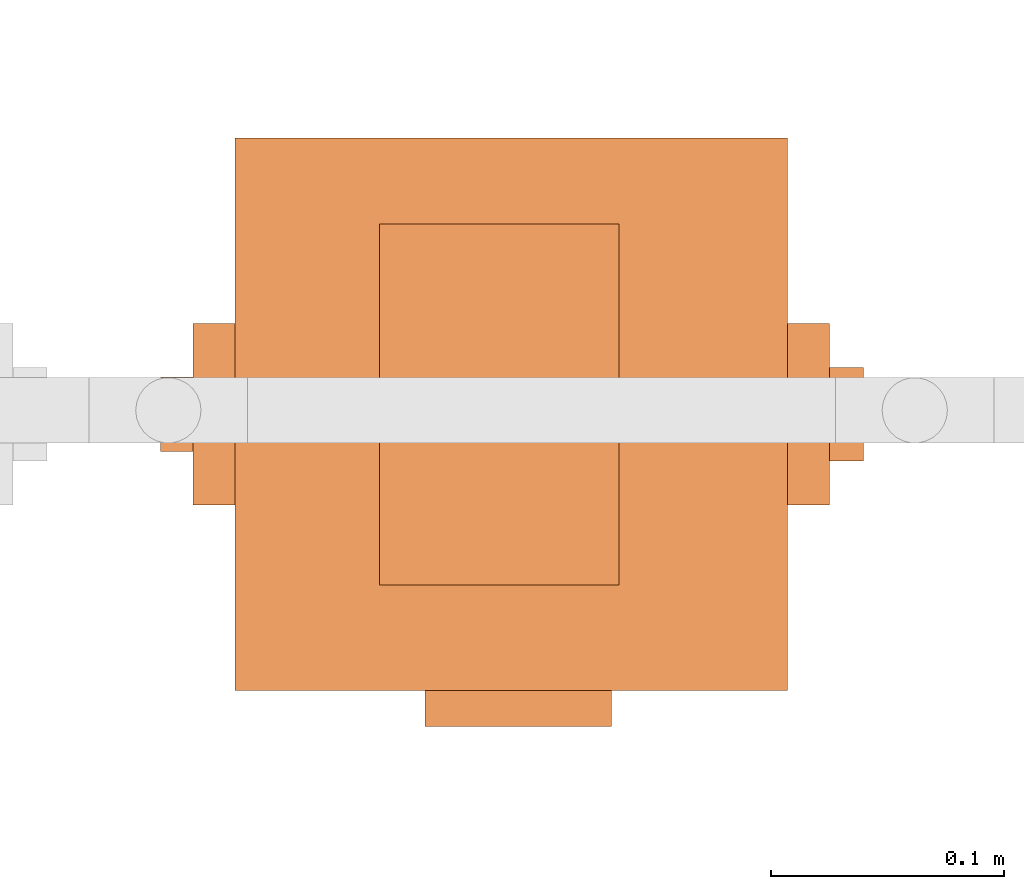
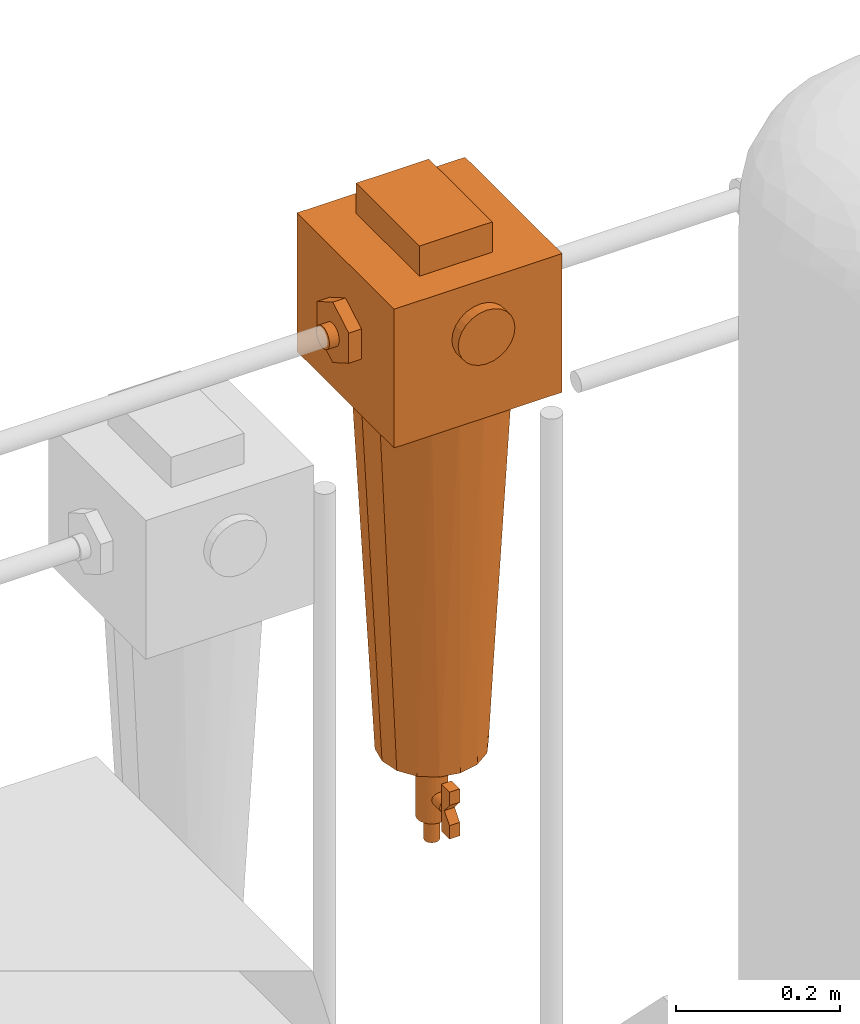
# One storey, part 330 of 331: 1 proxy.
"""IFC2X3 building model written with IfcOpenShell, lengths in millimetres."""

from ifc_helpers import new_model, entity, si_unit, converted_unit, derived_unit, direction, frame, origin, place, context, subcontext, project, spatial, faceted_brep, source, transform, mapped, material, material_list, type_object, type_shapes, element, save


model = new_model("IFC2X3")

# Units and contexts
model_context = context("Model", 3, precision=0.01, world=origin(), true_north=direction((6.12303176911189e-17, 1.0)))
body_context = subcontext(model_context, "Body", "Model", "MODEL_VIEW")
ifc_project = project(units=[si_unit("LENGTHUNIT", "METRE", prefix="MILLI"), si_unit("AREAUNIT", "SQUARE_METRE"), si_unit("VOLUMEUNIT", "CUBIC_METRE"), converted_unit("PLANEANGLEUNIT", "DEGREE", entity("IfcRatioMeasure", 0.0174532925199433), si_unit("PLANEANGLEUNIT", "RADIAN"), dimensions=[0, 0, 0, 0, 0, 0, 0]), si_unit("MASSUNIT", "GRAM", prefix="KILO"), derived_unit("MASSDENSITYUNIT", [(si_unit("MASSUNIT", "GRAM", prefix="KILO"), 1), (si_unit("LENGTHUNIT", "METRE"), -3)]), derived_unit("MOMENTOFINERTIAUNIT", [(si_unit("LENGTHUNIT", "METRE"), 4)]), si_unit("TIMEUNIT", "SECOND"), si_unit("FREQUENCYUNIT", "HERTZ"), si_unit("THERMODYNAMICTEMPERATUREUNIT", "DEGREE_CELSIUS"), derived_unit("THERMALTRANSMITTANCEUNIT", [(si_unit("MASSUNIT", "GRAM", prefix="KILO"), 1), (si_unit("THERMODYNAMICTEMPERATUREUNIT", "KELVIN"), -1), (si_unit("TIMEUNIT", "SECOND"), -3)]), derived_unit("VOLUMETRICFLOWRATEUNIT", [(si_unit("LENGTHUNIT", "METRE"), 3), (si_unit("TIMEUNIT", "SECOND"), -1)]), derived_unit("MASSFLOWRATEUNIT", [(si_unit("MASSUNIT", "GRAM", prefix="KILO"), 1), (si_unit("TIMEUNIT", "SECOND"), -1)]), derived_unit("ROTATIONALFREQUENCYUNIT", [(si_unit("TIMEUNIT", "SECOND"), -1)]), si_unit("ELECTRICCURRENTUNIT", "AMPERE"), si_unit("ELECTRICVOLTAGEUNIT", "VOLT"), si_unit("POWERUNIT", "WATT"), si_unit("FORCEUNIT", "NEWTON", prefix="KILO"), si_unit("ILLUMINANCEUNIT", "LUX"), si_unit("LUMINOUSFLUXUNIT", "LUMEN"), si_unit("LUMINOUSINTENSITYUNIT", "CANDELA"), derived_unit("USERDEFINED", [(si_unit("MASSUNIT", "GRAM", prefix="KILO"), -1), (si_unit("LENGTHUNIT", "METRE"), -2), (si_unit("TIMEUNIT", "SECOND"), 3), (si_unit("LUMINOUSFLUXUNIT", "LUMEN"), 1)]), derived_unit("LINEARVELOCITYUNIT", [(si_unit("LENGTHUNIT", "METRE"), 1), (si_unit("TIMEUNIT", "SECOND"), -1)]), si_unit("PRESSUREUNIT", "PASCAL"), derived_unit("USERDEFINED", [(si_unit("LENGTHUNIT", "METRE"), -2), (si_unit("MASSUNIT", "GRAM", prefix="KILO"), 1), (si_unit("TIMEUNIT", "SECOND"), -2)]), derived_unit("LINEARFORCEUNIT", [(si_unit("MASSUNIT", "GRAM", prefix="KILO"), 1), (si_unit("LENGTHUNIT", "METRE"), 1), (si_unit("TIMEUNIT", "SECOND"), -2), (si_unit("LENGTHUNIT", "METRE"), -1)]), derived_unit("PLANARFORCEUNIT", [(si_unit("MASSUNIT", "GRAM", prefix="KILO"), 1), (si_unit("LENGTHUNIT", "METRE"), 1), (si_unit("TIMEUNIT", "SECOND"), -2), (si_unit("LENGTHUNIT", "METRE"), -2)])], contexts=[model_context])

# Site, building, storey
site_placement = place(None, frame((0.0, -0.00077364408347762, 0.0)))
site = spatial("IfcSite", under=ifc_project, at=site_placement, CompositionType="ELEMENT")
building_placement = place(site_placement, origin())
building = spatial("IfcBuilding", under=site, at=building_placement, CompositionType="ELEMENT")
storey_placement = place(building_placement, origin())
storey = spatial("IfcBuildingStorey", under=building, at=storey_placement, CompositionType="ELEMENT", Elevation=0.0)

# Proxy
ifc_material_1 = material()
ifc_material_2 = material()
ifc_material_list = material_list([ifc_material_1, ifc_material_2])
building_element_proxy_type = type_object("IfcBuildingElementProxyType", PredefinedType="NOTDEFINED", material=ifc_material_1)
shared_shape = source(origin(), body_context, "Body", "Brep", [
    faceted_brep([(0.0, -133.944326212679, 215.362410286268), (-10.3527618041006, -133.944326212679, 213.999443337831), (-20.0, -133.944326212679, 210.003426437646), (-28.2842712474617, -133.944326212679, 203.64668153373), (-34.6410161513774, -133.944326212679, 195.362410286268), (-38.6370330515627, -133.944326212679, 185.715172090369), (-40.0, -133.944326212679, 175.362410286268), (-38.6370330515627, -133.944326212679, 165.009648482167), (-34.6410161513776, -133.944326212679, 155.362410286268), (-28.2842712474619, -133.944326212679, 147.078139038806), (-20.0, -133.944326212679, 140.721394134891), (-10.3527618041009, -133.944326212679, 136.725377234705), (0.0, -133.944326212679, 135.362410286268), (10.3527618041008, -133.944326212679, 136.725377234705), (20.0, -133.944326212679, 140.721394134891), (28.2842712474618, -133.944326212679, 147.078139038806), (34.6410161513775, -133.944326212679, 155.362410286268), (38.6370330515627, -133.944326212679, 165.009648482167), (40.0, -133.944326212679, 175.362410286268), (38.6370330515628, -133.944326212679, 185.715172090369), (34.6410161513776, -133.944326212679, 195.362410286268), (28.284271247462, -133.944326212679, 203.64668153373), (20.0, -133.944326212679, 210.003426437646), (10.352761804101, -133.944326212679, 213.999443337831), (0.0, -118.499999999999, 135.362410286268), (-10.3527618041009, -118.499999999999, 136.725377234705), (-20.0, -118.499999999999, 140.721394134891), (-28.2842712474619, -118.499999999999, 147.078139038806), (-34.6410161513776, -118.499999999999, 155.362410286268), (-38.6370330515627, -118.499999999999, 165.009648482167), (-40.0, -118.499999999999, 175.362410286268), (-38.6370330515627, -118.499999999999, 185.715172090369), (-34.6410161513774, -118.499999999999, 195.362410286268), (-28.2842712474617, -118.499999999999, 203.64668153373), (-20.0, -118.499999999999, 210.003426437646), (-10.3527618041006, -118.499999999999, 213.999443337831), (0.0, -118.499999999999, 215.362410286268), (10.352761804101, -118.499999999999, 213.999443337831), (20.0, -118.499999999999, 210.003426437646), (28.284271247462, -118.499999999999, 203.64668153373), (34.6410161513776, -118.499999999999, 195.362410286268), (38.6370330515628, -118.499999999999, 185.715172090369), (40.0, -118.499999999999, 175.362410286268), (38.6370330515627, -118.499999999999, 165.009648482167), (34.6410161513775, -118.499999999999, 155.362410286268), (28.2842712474618, -118.499999999999, 147.078139038806), (20.0, -118.499999999999, 140.721394134891), (10.3527618041008, -118.499999999999, 136.725377234705)], [[[0, 1, 2, 3, 4, 5, 6, 7, 8, 9, 10, 11, 12, 13, 14, 15, 16, 17, 18, 19, 20, 21, 22, 23]], [[24, 25, 26, 27, 28, 29, 30, 31, 32, 33, 34, 35, 36, 37, 38, 39, 40, 41, 42, 43, 44, 45, 46, 47]], [[41, 19, 18, 42]], [[40, 20, 19, 41]], [[22, 21, 39, 38]], [[40, 39, 21, 20]], [[23, 22, 38, 37]], [[0, 23, 37, 36]], [[35, 1, 0, 36]], [[34, 2, 1, 35]], [[4, 3, 33, 32]], [[34, 33, 3, 2]], [[5, 4, 32, 31]], [[6, 5, 31, 30]], [[29, 7, 6, 30]], [[28, 8, 7, 29]], [[10, 9, 27, 26]], [[28, 27, 9, 8]], [[11, 10, 26, 25]], [[12, 11, 25, 24]], [[47, 13, 12, 24]], [[46, 14, 13, 47]], [[16, 15, 45, 44]], [[46, 45, 15, 14]], [[17, 16, 44, 43]], [[18, 17, 43, 42]]]),
    faceted_brep([(43.1099584355239, 81.5000000000009, 295.027035784925), (-59.5, 81.5000000000009, 295.027035784925), (-59.5, -73.1694472627613, 295.027035784925), (43.1099584355239, -73.1694472627613, 295.027035784925), (43.1099584355239, 81.5000000000009, 250.0), (43.1099584355239, -73.1694472627613, 250.0), (-59.5, -73.1694472627613, 250.0), (-59.5, 81.5000000000009, 250.0)], [[[0, 1, 2, 3]], [[4, 5, 6, 7]], [[1, 0, 4, 7]], [[2, 1, 7, 6]], [[3, 2, 6, 5]], [[0, 3, 5, 4]]]),
    faceted_brep([(6.83332917429858, -36.7004123407108, -547.095544544356), (6.83332917429858, -56.7004123407108, -547.095544544356), (6.83332917429858, -56.7004123407108, -567.095544544356), (6.83332917429858, -44.1139178730516, -582.095544544356), (6.83332917429858, -56.7004123407108, -597.095544544356), (6.83332917429858, -56.7004123407109, -617.095544544356), (6.83332917429858, -36.7004123407109, -617.095544544356), (6.83332917429858, -36.7004123407108, -582.095544544356), (-7.69905295378288, -36.7004123407108, -547.095544544356), (-7.69905295378288, -36.7004123407108, -582.095544544356), (-7.69905295378288, -36.7004123407109, -617.095544544356), (-7.69905295378288, -56.7004123407109, -617.095544544356), (-7.69905295378288, -56.7004123407108, -597.095544544356), (-7.69905295378288, -44.1139178730516, -582.095544544356), (-7.69905295378288, -56.7004123407108, -567.095544544356), (-7.69905295378288, -56.7004123407108, -547.095544544356)], [[[0, 1, 2, 3, 4, 5, 6, 7]], [[8, 9, 10, 11, 12, 13, 14, 15]], [[1, 0, 8, 15]], [[2, 1, 15, 14]], [[3, 2, 14, 13]], [[4, 3, 13, 12]], [[5, 4, 12, 11]], [[6, 5, 11, 10]], [[7, 6, 10, 9]], [[0, 7, 9, 8]]]),
    faceted_brep([(-5.0, -36.7004123407108, -573.435290506511), (-7.07106781186544, -36.7004123407108, -575.02447673249), (-8.66025403784436, -36.7004123407108, -577.095544544356), (-9.65925826289067, -36.7004123407108, -579.50735409333), (-10.0, -36.7004123407108, -582.095544544356), (-9.65925826289068, -36.7004123407108, -584.683734995381), (-8.66025403784439, -36.7004123407108, -587.095544544356), (-7.07106781186548, -36.7004123407108, -589.166612356221), (-5.0, -36.7004123407108, -590.7557985822), (-2.58819045102522, -36.7004123407108, -591.754802807246), (0.0, -36.7004123407108, -592.095544544356), (2.58819045102519, -36.7004123407108, -591.754802807246), (5.0, -36.7004123407108, -590.7557985822), (7.07106781186546, -36.7004123407108, -589.166612356221), (8.66025403784437, -36.7004123407108, -587.095544544356), (9.65925826289068, -36.7004123407108, -584.683734995381), (10.0, -36.7004123407108, -582.095544544356), (9.65925826289069, -36.7004123407108, -579.50735409333), (8.66025403784441, -36.7004123407108, -577.095544544356), (7.0710678118655, -36.7004123407108, -575.02447673249), (5.0, -36.7004123407108, -573.435290506511), (2.58819045102525, -36.7004123407108, -572.436286281465), (0.0, -36.7004123407108, -572.095544544356), (-2.58819045102516, -36.7004123407108, -572.436286281465), (2.58819045102519, -9.5868948994194, -591.754802807246), (0.0, -9.5868948994194, -592.095544544356), (-2.58819045102522, -9.5868948994194, -591.754802807246), (-5.0, -9.5868948994194, -590.7557985822), (-7.07106781186548, -9.5868948994194, -589.166612356221), (-8.66025403784439, -9.5868948994194, -587.095544544356), (-9.65925826289068, -9.5868948994194, -584.683734995381), (-10.0, -9.5868948994194, -582.095544544356), (-9.65925826289067, -9.5868948994194, -579.50735409333), (-8.66025403784436, -9.5868948994194, -577.095544544356), (-7.07106781186544, -9.5868948994194, -575.02447673249), (-5.0, -9.5868948994194, -573.435290506511), (-2.58819045102516, -9.5868948994194, -572.436286281465), (0.0, -9.5868948994194, -572.095544544356), (2.58819045102525, -9.5868948994194, -572.436286281465), (5.0, -9.5868948994194, -573.435290506511), (7.0710678118655, -9.5868948994194, -575.02447673249), (8.66025403784441, -9.5868948994194, -577.095544544356), (9.65925826289069, -9.5868948994194, -579.50735409333), (10.0, -9.5868948994194, -582.095544544356), (9.65925826289068, -9.5868948994194, -584.683734995381), (8.66025403784437, -9.5868948994194, -587.095544544356), (7.07106781186546, -9.5868948994194, -589.166612356221), (5.0, -9.5868948994194, -590.7557985822)], [[[0, 1, 2, 3, 4, 5, 6, 7, 8, 9, 10, 11, 12, 13, 14, 15, 16, 17, 18, 19, 20, 21, 22, 23]], [[24, 25, 26, 27, 28, 29, 30, 31, 32, 33, 34, 35, 36, 37, 38, 39, 40, 41, 42, 43, 44, 45, 46, 47]], [[42, 17, 16, 43]], [[41, 18, 17, 42]], [[20, 19, 40, 39]], [[41, 40, 19, 18]], [[21, 20, 39, 38]], [[22, 21, 38, 37]], [[36, 23, 22, 37]], [[35, 0, 23, 36]], [[2, 1, 34, 33]], [[35, 34, 1, 0]], [[3, 2, 33, 32]], [[4, 3, 32, 31]], [[30, 5, 4, 31]], [[29, 6, 5, 30]], [[8, 7, 28, 27]], [[29, 28, 7, 6]], [[9, 8, 27, 26]], [[10, 9, 26, 25]], [[24, 11, 10, 25]], [[47, 12, 11, 24]], [[14, 13, 46, 45]], [[47, 46, 13, 12]], [[15, 14, 45, 44]], [[16, 15, 44, 43]]]),
    faceted_brep([(5.17638090205032, -19.3185165257814, -545.770195770574), (10.0, -17.3205080756888, -545.770195770574), (14.1421356237309, -14.142135623731, -545.770195770574), (17.3205080756887, -10.0, -545.770195770574), (19.3185165257813, -5.17638090205054, -545.770195770574), (20.0, 0.0, -545.770195770574), (19.3185165257814, 5.17638090205041, -545.770195770574), (17.3205080756888, 10.0, -545.770195770574), (14.142135623731, 14.1421356237309, -545.770195770574), (10.0, 17.3205080756888, -545.770195770574), (5.17638090205044, 19.3185165257814, -545.770195770574), (0.0, 20.0, -545.770195770574), (-5.17638090205038, 19.3185165257814, -545.770195770574), (-10.0, 17.3205080756888, -545.770195770574), (-14.1421356237309, 14.142135623731, -545.770195770574), (-17.3205080756888, 10.0, -545.770195770574), (-19.3185165257814, 5.17638090205047, -545.770195770574), (-20.0, 0.0, -545.770195770574), (-19.3185165257814, -5.17638090205035, -545.770195770574), (-17.3205080756888, -10.0, -545.770195770574), (-14.142135623731, -14.1421356237309, -545.770195770574), (-10.0, -17.3205080756887, -545.770195770574), (-5.1763809020505, -19.3185165257813, -545.770195770574), (0.0, -20.0, -545.770195770574), (0.0, 20.0, -617.574154599676), (5.17638090205044, 19.3185165257814, -617.574154599676), (10.0, 17.3205080756888, -617.574154599676), (14.142135623731, 14.1421356237309, -617.574154599676), (17.3205080756888, 10.0, -617.574154599676), (19.3185165257814, 5.17638090205041, -617.574154599676), (20.0, 0.0, -617.574154599676), (19.3185165257813, -5.17638090205054, -617.574154599676), (17.3205080756887, -10.0, -617.574154599676), (14.1421356237309, -14.142135623731, -617.574154599676), (10.0, -17.3205080756888, -617.574154599676), (5.17638090205032, -19.3185165257814, -617.574154599676), (0.0, -20.0, -617.574154599676), (-5.1763809020505, -19.3185165257813, -617.574154599676), (-10.0, -17.3205080756887, -617.574154599676), (-14.142135623731, -14.1421356237309, -617.574154599676), (-17.3205080756888, -10.0, -617.574154599676), (-19.3185165257814, -5.17638090205035, -617.574154599676), (-20.0, 0.0, -617.574154599676), (-19.3185165257814, 5.17638090205047, -617.574154599676), (-17.3205080756888, 10.0, -617.574154599676), (-14.1421356237309, 14.142135623731, -617.574154599676), (-10.0, 17.3205080756888, -617.574154599676), (-5.17638090205038, 19.3185165257814, -617.574154599676)], [[[0, 1, 2, 3, 4, 5, 6, 7, 8, 9, 10, 11, 12, 13, 14, 15, 16, 17, 18, 19, 20, 21, 22, 23]], [[24, 25, 26, 27, 28, 29, 30, 31, 32, 33, 34, 35, 36, 37, 38, 39, 40, 41, 42, 43, 44, 45, 46, 47]], [[18, 41, 40, 19]], [[39, 20, 19, 40]], [[21, 38, 37, 22]], [[39, 38, 21, 20]], [[22, 37, 36, 23]], [[41, 18, 17, 42]], [[0, 35, 34, 1]], [[33, 2, 1, 34]], [[3, 32, 31, 4]], [[33, 32, 3, 2]], [[4, 31, 30, 5]], [[35, 0, 23, 36]], [[30, 29, 6, 5]], [[9, 26, 25, 10]], [[26, 9, 8, 27]], [[10, 25, 24, 11]], [[29, 28, 7, 6]], [[28, 27, 8, 7]], [[12, 47, 46, 13]], [[45, 14, 13, 46]], [[15, 44, 43, 16]], [[45, 44, 15, 14]], [[16, 43, 42, 17]], [[47, 12, 11, 24]]]),
    faceted_brep([(2.58819045102516, -9.6592582628907, -513.126445637314), (5.0, -8.66025403784441, -513.126445637314), (7.07106781186544, -7.07106781186551, -513.126445637314), (8.66025403784436, -5.0, -513.126445637314), (9.65925826289067, -2.58819045102527, -513.126445637314), (10.0, 0.0, -513.126445637314), (9.65925826289068, 2.58819045102521, -513.126445637314), (8.66025403784439, 5.0, -513.126445637314), (7.07106781186548, 7.07106781186547, -513.126445637314), (5.0, 8.66025403784438, -513.126445637314), (2.58819045102522, 9.65925826289068, -513.126445637314), (0.0, 10.0, -513.126445637314), (-2.58819045102519, 9.65925826289069, -513.126445637314), (-5.0, 8.6602540378444, -513.126445637314), (-7.07106781186546, 7.07106781186549, -513.126445637314), (-8.66025403784437, 5.0, -513.126445637314), (-9.65925826289068, 2.58819045102524, -513.126445637314), (-10.0, 0.0, -513.126445637314), (-9.65925826289069, -2.58819045102517, -513.126445637314), (-8.66025403784441, -5.0, -513.126445637314), (-7.0710678118655, -7.07106781186545, -513.126445637314), (-5.0, -8.66025403784437, -513.126445637314), (-2.58819045102525, -9.65925826289067, -513.126445637314), (0.0, -10.0, -513.126445637314), (0.0, 10.0, -652.602700358113), (2.58819045102522, 9.65925826289068, -652.602700358113), (5.0, 8.66025403784438, -652.602700358113), (7.07106781186548, 7.07106781186547, -652.602700358113), (8.66025403784439, 5.0, -652.602700358113), (9.65925826289068, 2.58819045102521, -652.602700358113), (10.0, 0.0, -652.602700358113), (9.65925826289067, -2.58819045102527, -652.602700358113), (8.66025403784436, -5.0, -652.602700358113), (7.07106781186544, -7.07106781186551, -652.602700358113), (5.0, -8.66025403784441, -652.602700358113), (2.58819045102516, -9.6592582628907, -652.602700358113), (0.0, -10.0, -652.602700358113), (-2.58819045102525, -9.65925826289067, -652.602700358113), (-5.0, -8.66025403784437, -652.602700358113), (-7.0710678118655, -7.07106781186545, -652.602700358113), (-8.66025403784441, -5.0, -652.602700358113), (-9.65925826289069, -2.58819045102517, -652.602700358113), (-10.0, 0.0, -652.602700358113), (-9.65925826289068, 2.58819045102524, -652.602700358113), (-8.66025403784437, 5.0, -652.602700358113), (-7.07106781186546, 7.07106781186549, -652.602700358113), (-5.0, 8.6602540378444, -652.602700358113), (-2.58819045102519, 9.65925826289069, -652.602700358113)], [[[0, 1, 2, 3, 4, 5, 6, 7, 8, 9, 10, 11, 12, 13, 14, 15, 16, 17, 18, 19, 20, 21, 22, 23]], [[24, 25, 26, 27, 28, 29, 30, 31, 32, 33, 34, 35, 36, 37, 38, 39, 40, 41, 42, 43, 44, 45, 46, 47]], [[41, 18, 17, 42]], [[40, 19, 18, 41]], [[21, 20, 39, 38]], [[40, 39, 20, 19]], [[22, 21, 38, 37]], [[23, 22, 37, 36]], [[35, 0, 23, 36]], [[3, 32, 31, 4]], [[32, 3, 2, 33]], [[4, 31, 30, 5]], [[0, 35, 34, 1]], [[1, 34, 33, 2]], [[29, 6, 5, 30]], [[28, 7, 6, 29]], [[9, 8, 27, 26]], [[28, 27, 8, 7]], [[9, 26, 25, 10]], [[24, 11, 10, 25]], [[14, 13, 46, 45]], [[15, 44, 43, 16]], [[45, 44, 15, 14]], [[16, 43, 42, 17]], [[47, 46, 13, 12]], [[12, 11, 24, 47]]]),
    faceted_brep([(-121.5, 0.0, 105.0), (-121.5, 38.9711431702997, 127.5), (-121.5, 38.9711431702998, 172.5), (-121.5, 0.0, 195.0), (-121.5, -38.9711431702996, 172.500000000001), (-121.5, -38.9711431702999, 127.500000000001), (-139.459825523657, 0.0, 105.0), (-139.459825523657, -38.9711431702999, 127.500000000001), (-139.459825523657, -38.9711431702996, 172.500000000001), (-139.459825523657, 0.0, 195.0), (-139.459825523657, 38.9711431702998, 172.5), (-139.459825523657, 38.9711431702997, 127.5)], [[[0, 1, 2, 3, 4, 5]], [[6, 7, 8, 9, 10, 11]], [[1, 0, 6, 11]], [[2, 1, 11, 10]], [[3, 2, 10, 9]], [[4, 3, 9, 8]], [[5, 4, 8, 7]], [[0, 5, 7, 6]]]),
    faceted_brep([(133.459825523657, 0.0, 105.0), (133.459825523657, 38.9711431702997, 127.5), (133.459825523657, 38.9711431702998, 172.5), (133.459825523657, 0.0, 195.0), (133.459825523657, -38.9711431702996, 172.5), (133.459825523657, -38.9711431702999, 127.5), (115.5, 0.0, 105.0), (115.5, -38.9711431702999, 127.5), (115.5, -38.9711431702996, 172.5), (115.5, 0.0, 195.0), (115.5, 38.9711431702998, 172.5), (115.5, 38.9711431702997, 127.5)], [[[0, 1, 2, 3, 4, 5]], [[6, 7, 8, 9, 10, 11]], [[1, 0, 6, 11]], [[2, 1, 11, 10]], [[3, 2, 10, 9]], [[4, 3, 9, 8]], [[5, 4, 8, 7]], [[0, 5, 7, 6]]]),
    faceted_brep([(-153.337340449734, 4.14110472164035, 162.941988222046), (-153.337340449734, 8.0, 161.343581461972), (-153.337340449734, 11.3137084989848, 158.800883500406), (-153.337340449734, 13.856406460551, 155.487175001421), (-153.337340449734, 15.4548132206251, 151.628279723061), (-153.337340449734, 16.0, 147.487175001421), (-153.337340449734, 15.4548132206251, 143.346070279781), (-153.337340449734, 13.856406460551, 139.487175001421), (-153.337340449734, 11.3137084989847, 136.173466502436), (-153.337340449734, 8.0, 133.63076854087), (-153.337340449734, 4.14110472164026, 132.032361780796), (-153.337340449734, 0.0, 131.487175001421), (-153.337340449734, -4.1411047216404, 132.032361780796), (-153.337340449734, -8.0, 133.63076854087), (-153.337340449734, -11.3137084989848, 136.173466502436), (-153.337340449734, -13.8564064605511, 139.487175001421), (-153.337340449734, -15.4548132206251, 143.346070279781), (-153.337340449734, -16.0, 147.487175001421), (-153.337340449734, -15.4548132206251, 151.628279723061), (-153.337340449734, -13.856406460551, 155.487175001421), (-153.337340449734, -11.3137084989847, 158.800883500406), (-153.337340449734, -8.0, 161.343581461972), (-153.337340449734, -4.14110472164031, 162.941988222046), (-153.337340449734, 0.0, 163.487175001421), (-139.459825523657, 4.14110472164026, 132.032361780796), (-139.459825523657, 8.0, 133.63076854087), (-139.459825523657, 11.3137084989847, 136.173466502436), (-139.459825523657, 13.856406460551, 139.487175001421), (-139.459825523657, 15.4548132206251, 143.346070279781), (-139.459825523657, 16.0, 147.487175001421), (-139.459825523657, 15.4548132206251, 151.628279723061), (-139.459825523657, 13.856406460551, 155.487175001421), (-139.459825523657, 11.3137084989848, 158.800883500406), (-139.459825523657, 8.0, 161.343581461972), (-139.459825523657, 4.14110472164035, 162.941988222046), (-139.459825523657, 0.0, 163.487175001421), (-139.459825523657, -4.14110472164031, 162.941988222046), (-139.459825523657, -8.0, 161.343581461972), (-139.459825523657, -11.3137084989847, 158.800883500406), (-139.459825523657, -13.856406460551, 155.487175001421), (-139.459825523657, -15.4548132206251, 151.628279723061), (-139.459825523657, -16.0, 147.487175001421), (-139.459825523657, -15.4548132206251, 143.346070279781), (-139.459825523657, -13.8564064605511, 139.487175001421), (-139.459825523657, -11.3137084989848, 136.173466502436), (-139.459825523657, -8.0, 133.63076854087), (-139.459825523657, -4.1411047216404, 132.032361780796), (-139.459825523657, 0.0, 131.487175001421)], [[[0, 1, 2, 3, 4, 5, 6, 7, 8, 9, 10, 11, 12, 13, 14, 15, 16, 17, 18, 19, 20, 21, 22, 23]], [[24, 25, 26, 27, 28, 29, 30, 31, 32, 33, 34, 35, 36, 37, 38, 39, 40, 41, 42, 43, 44, 45, 46, 47]], [[16, 42, 41, 17]], [[15, 43, 42, 16]], [[45, 44, 14, 13]], [[15, 14, 44, 43]], [[46, 45, 13, 12]], [[47, 46, 12, 11]], [[10, 24, 47, 11]], [[9, 25, 24, 10]], [[27, 26, 8, 7]], [[9, 8, 26, 25]], [[28, 27, 7, 6]], [[29, 28, 6, 5]], [[4, 30, 29, 5]], [[3, 31, 30, 4]], [[33, 32, 2, 1]], [[3, 2, 32, 31]], [[34, 33, 1, 0]], [[35, 34, 0, 23]], [[22, 36, 35, 23]], [[21, 37, 36, 22]], [[21, 20, 38, 37]], [[20, 19, 39, 38]], [[18, 40, 39, 19]], [[18, 17, 41, 40]]]),
    faceted_brep([(147.995639473242, -10.0, 165.507212653008), (147.995639473242, -14.1421356237309, 162.32884020105), (147.995639473242, -17.3205080756887, 158.186704577319), (147.995639473242, -19.3185165257813, 153.36308547937), (147.995639473242, -20.0, 148.186704577319), (147.995639473242, -19.3185165257814, 143.010323675269), (147.995639473242, -17.3205080756888, 138.186704577319), (147.995639473242, -14.142135623731, 134.044568953588), (147.995639473242, -10.0, 130.86619650163), (147.995639473242, -5.17638090205044, 128.868188051538), (147.995639473242, 0.0, 128.186704577319), (147.995639473242, 5.17638090205038, 128.868188051538), (147.995639473242, 10.0, 130.86619650163), (147.995639473242, 14.1421356237309, 134.044568953588), (147.995639473242, 17.3205080756888, 138.186704577319), (147.995639473242, 19.3185165257814, 143.010323675269), (147.995639473242, 20.0, 148.186704577319), (147.995639473242, 19.3185165257814, 153.363085479369), (147.995639473242, 17.3205080756888, 158.186704577319), (147.995639473242, 14.142135623731, 162.32884020105), (147.995639473242, 10.0, 165.507212653008), (147.995639473242, 5.1763809020505, 167.5052211031), (147.995639473242, 0.0, 168.186704577319), (147.995639473242, -5.17638090205032, 167.505221103101), (133.459825523657, 0.0, 128.186704577319), (133.459825523657, -5.17638090205044, 128.868188051538), (133.459825523657, -10.0, 130.86619650163), (133.459825523657, -14.142135623731, 134.044568953588), (133.459825523657, -17.3205080756888, 138.186704577319), (133.459825523657, -19.3185165257814, 143.010323675269), (133.459825523657, -20.0, 148.186704577319), (133.459825523657, -19.3185165257813, 153.36308547937), (133.459825523657, -17.3205080756887, 158.186704577319), (133.459825523657, -14.1421356237309, 162.32884020105), (133.459825523657, -10.0, 165.507212653008), (133.459825523657, -5.17638090205032, 167.505221103101), (133.459825523657, 0.0, 168.186704577319), (133.459825523657, 5.1763809020505, 167.5052211031), (133.459825523657, 10.0, 165.507212653008), (133.459825523657, 14.142135623731, 162.32884020105), (133.459825523657, 17.3205080756888, 158.186704577319), (133.459825523657, 19.3185165257814, 153.363085479369), (133.459825523657, 20.0, 148.186704577319), (133.459825523657, 19.3185165257814, 143.010323675269), (133.459825523657, 17.3205080756888, 138.186704577319), (133.459825523657, 14.1421356237309, 134.044568953588), (133.459825523657, 10.0, 130.86619650163), (133.459825523657, 5.17638090205038, 128.868188051538)], [[[0, 1, 2, 3, 4, 5, 6, 7, 8, 9, 10, 11, 12, 13, 14, 15, 16, 17, 18, 19, 20, 21, 22, 23]], [[24, 25, 26, 27, 28, 29, 30, 31, 32, 33, 34, 35, 36, 37, 38, 39, 40, 41, 42, 43, 44, 45, 46, 47]], [[41, 17, 16, 42]], [[40, 18, 17, 41]], [[20, 19, 39, 38]], [[40, 39, 19, 18]], [[21, 20, 38, 37]], [[22, 21, 37, 36]], [[35, 23, 22, 36]], [[34, 0, 23, 35]], [[2, 1, 33, 32]], [[34, 33, 1, 0]], [[3, 2, 32, 31]], [[4, 3, 31, 30]], [[29, 5, 4, 30]], [[28, 6, 5, 29]], [[8, 7, 27, 26]], [[28, 27, 7, 6]], [[9, 8, 26, 25]], [[10, 9, 25, 24]], [[47, 11, 10, 24]], [[46, 12, 11, 47]], [[45, 44, 14, 13]], [[46, 45, 13, 12]], [[15, 43, 42, 16]], [[15, 14, 44, 43]]]),
    faceted_brep([(-64.6715672757874, -26.7878402655554, -513.126445637314), (-67.3357836378922, -13.3939201327778, -513.126445637314), (-70.0, 0.0, -513.126445637314), (-67.3357836378947, 13.3939201327778, -513.126445637314), (-64.6715672757897, 26.7878402655559, -513.126445637314), (-57.0845209794239, 38.1426574743067, -513.126445637314), (-49.497474683058, 49.4974746830576, -513.126445637314), (-38.1426574743071, 57.0845209794232, -513.126445637314), (-26.7878402655561, 64.6715672757889, -513.126445637314), (-13.3939201327782, 67.3357836378936, -513.126445637314), (0.0, 70.0, -513.126445637314), (13.3939201327774, 67.3357836378933, -513.126445637314), (26.7878402655551, 64.6715672757882, -513.126445637314), (38.1426574743057, 57.0845209794225, -513.126445637314), (49.4974746830562, 49.4974746830568, -513.126445637314), (57.0845209794218, 38.1426574743062, -513.126445637314), (64.6715672757873, 26.7878402655556, -513.126445637314), (67.3357836378922, 13.393920132778, -513.126445637314), (70.0, 0.0, -513.126445637314), (67.3357836378946, -13.393920132778, -513.126445637314), (64.6715672757896, -26.7878402655561, -513.126445637314), (57.0845209794237, -38.1426574743069, -513.126445637314), (49.4974746830578, -49.4974746830577, -513.126445637314), (38.1426574743069, -57.0845209794233, -513.126445637314), (26.7878402655559, -64.6715672757889, -513.126445637314), (13.393920132778, -67.3357836378937, -513.126445637314), (0.0, -70.0, -513.126445637314), (-13.3939201327776, -67.3357836378932, -513.126445637314), (-26.7878402655553, -64.6715672757881, -513.126445637314), (-38.1426574743059, -57.0845209794224, -513.126445637314), (-49.4974746830564, -49.4974746830566, -513.126445637314), (-57.0845209794219, -38.142657474306, -513.126445637314), (-100.0, 0.0, 43.2779488123182), (-93.9692620785884, -34.2020143325663, 43.2779488123182), (-76.6044443118959, -64.2787609686527, 43.2779488123182), (-50.0, -86.6025403784423, 43.2779488123182), (-17.3648177666926, -98.4807753012194, 43.2779488123182), (17.364817766693, -98.4807753012198, 43.2779488123182), (50.0, -86.6025403784433, 43.2779488123182), (76.6044443118976, -64.2787609686537, 43.2779488123182), (93.9692620785908, -34.2020143325668, 43.2779488123182), (100.0, 0.0, 43.2779488123182), (93.9692620785883, 34.2020143325666, 43.2779488123182), (76.6044443118957, 64.2787609686529, 43.2779488123182), (50.0, 86.6025403784425, 43.2779488123182), (17.3648177666923, 98.4807753012194, 43.2779488123182), (-17.3648177666933, 98.4807753012197, 43.2779488123182), (-50.0, 86.6025403784431, 43.2779488123182), (-76.6044443118979, 64.2787609686534, 43.2779488123182), (-93.9692620785909, 34.2020143325665, 43.2779488123182)], [[[0, 1, 2, 3, 4, 5, 6, 7, 8, 9, 10, 11, 12, 13, 14, 15, 16, 17, 18, 19, 20, 21, 22, 23, 24, 25, 26, 27, 28, 29, 30, 31]], [[32, 33, 34, 35, 36, 37, 38, 39, 40, 41, 42, 43, 44, 45, 46, 47, 48, 49]], [[41, 17, 42]], [[11, 10, 45, 12]], [[44, 14, 13, 12]], [[15, 14, 43]], [[49, 4, 3]], [[42, 15, 43]], [[14, 44, 43]], [[15, 42, 16]], [[12, 45, 44]], [[46, 10, 9, 8]], [[17, 16, 42]], [[4, 49, 5]], [[17, 41, 18]], [[2, 32, 3]], [[6, 47, 8, 7]], [[8, 47, 46]], [[48, 6, 5]], [[6, 48, 47]], [[3, 32, 49]], [[48, 5, 49]], [[10, 46, 45]], [[32, 1, 33]], [[27, 26, 36, 28]], [[35, 30, 29, 28]], [[31, 30, 34]], [[40, 20, 19]], [[33, 31, 34]], [[30, 35, 34]], [[31, 33, 0]], [[28, 36, 35]], [[37, 26, 25, 24]], [[1, 0, 33]], [[20, 40, 21]], [[1, 32, 2]], [[18, 41, 19]], [[22, 38, 24, 23]], [[24, 38, 37]], [[39, 22, 21]], [[22, 39, 38]], [[19, 41, 40]], [[39, 21, 40]], [[26, 37, 36]]]),
    faceted_brep([(-121.5, 118.5, 250.0), (-121.5, -118.499999999999, 250.0), (115.5, -118.5, 250.0), (115.5, 118.5, 250.0), (-121.5, 118.5, 43.2779488123182), (115.5, 118.5, 43.2779488123182), (115.5, -118.5, 43.2779488123182), (-121.5, -118.499999999999, 43.2779488123182)], [[[0, 1, 2, 3]], [[4, 5, 6, 7]], [[1, 0, 4, 7]], [[2, 1, 7, 6]], [[3, 2, 6, 5]], [[0, 3, 5, 4]]]),
])
type_shapes(building_element_proxy_type, [shared_shape])
proxy_placement = place(storey_placement, frame((53690.1085349589, -688.500101698472, 742.500000000002)))
element("IfcBuildingElementProxy", 1, at=proxy_placement, inside=storey, type_object=building_element_proxy_type, material=ifc_material_list, context=body_context, shape_type="MappedRepresentation", body=[
    mapped(shared_shape, transform((0.0, 0.0, 0.0), scale=1.0)),
])

save(model, "model.ifc")
